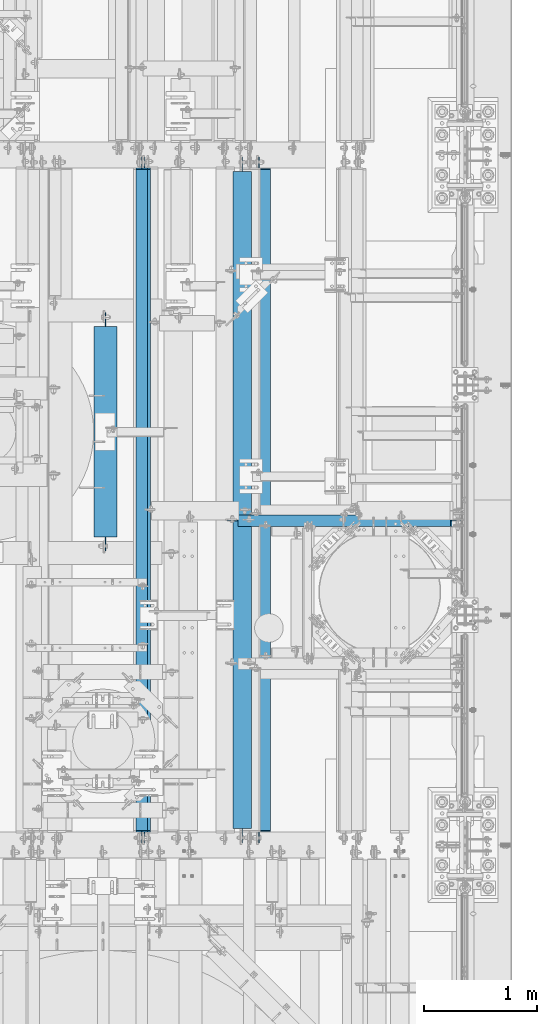
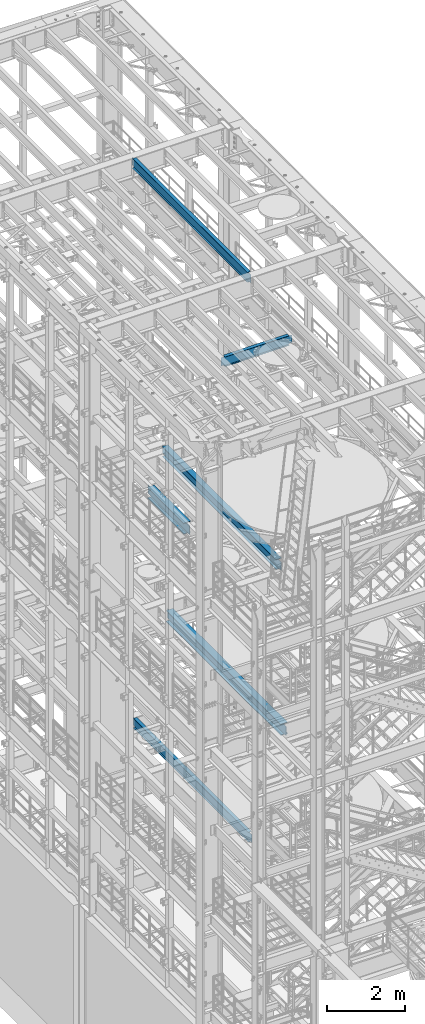
# One storey, part 1031 of 1876: 6 beams, 6 elements without a shape of their own.
"""IFC2X3 building model written with IfcOpenShell, lengths in millimetres."""

from ifc_helpers import new_model, si_unit, frame, origin_with_axes, place, context, subcontext, project, spatial, faceted_brep, material, type_object, element, aggregate, save


model = new_model("IFC2X3")

# Units and contexts
model_context = context("Model", 3, precision=1e-05, world=origin_with_axes())
body_context = subcontext(model_context, "Body", "Model", "MODEL_VIEW")
ifc_project = project(units=[si_unit("LENGTHUNIT", "METRE", prefix="MILLI"), si_unit("AREAUNIT", "SQUARE_METRE"), si_unit("VOLUMEUNIT", "CUBIC_METRE"), si_unit("MASSUNIT", "GRAM", prefix="KILO"), si_unit("TIMEUNIT", "SECOND"), si_unit("PLANEANGLEUNIT", "RADIAN"), si_unit("SOLIDANGLEUNIT", "STERADIAN"), si_unit("THERMODYNAMICTEMPERATUREUNIT", "DEGREE_CELSIUS"), si_unit("LUMINOUSINTENSITYUNIT", "LUMEN")], contexts=[model_context])

# Site, building, storey
site_placement = place(None, origin_with_axes())
site = spatial("IfcSite", under=ifc_project, at=site_placement, CompositionType="ELEMENT")
building_placement = place(site_placement, origin_with_axes())
building = spatial("IfcBuilding", under=site, at=building_placement, Name="Undefined", CompositionType="ELEMENT")
storey_placement = place(building_placement, origin_with_axes())
storey = spatial("IfcBuildingStorey", under=building, at=storey_placement, Name="Undefined", CompositionType="ELEMENT", Elevation=0.0)

# Assembly, beam
assembly_1_placement = place(storey_placement, origin_with_axes())
assembly_1 = element("IfcElementAssembly", 1, at=assembly_1_placement, inside=storey, Name="BEAM", AssemblyPlace="NOTDEFINED", PredefinedType="RIGID_FRAME")
ifc_material = material(Name="STEEL/A992")
beam_type_1 = type_object("IfcBeamType", Name="W12X16", PredefinedType="NOTDEFINED")
beam_1_placement = place(assembly_1_placement, frame((5638.8, 4387.85, 17830.8), z_axis=(0.0, 0.0, 1.0), x_axis=(1.0, 0.0, 0.0)))
beam_1 = element("IfcBeam", 2, at=beam_1_placement, type_object=beam_type_1, material=ifc_material, Name="BEAM", ObjectType="W12X16", context=body_context, shape_type="Brep", body=[
    faceted_brep([(1866.10625, -3.17500000000018, -146.049999999999), (1866.10625, -50.8000000000002, -146.049999999999), (1866.10625, -50.8000000000002, -152.400000000001), (1866.10625, 50.8000000000002, -152.400000000001), (1866.10625, 50.8000000000002, -146.049999999999), (1866.10625, 3.17500000000018, -146.049999999999), (1866.10625, 3.17500000000018, -139.699999809261), (1866.10625, -3.17500000000018, -139.699999809261), (1867.07297992259, 3.17500000000018, -134.839920291215), (1867.07297992259, -3.17500000000018, -134.839920291215), (1869.82599382306, 3.17500000000018, -130.719743823061), (1869.82599382306, -3.17500000000018, -130.719743823061), (1873.94617029122, 3.17500000000018, -127.966729922584), (1873.94617029122, -3.17500000000018, -127.966729922584), (1878.80624980926, 3.17500000000018, -126.999999999996), (1878.80624980926, -3.17500000000018, -126.999999999996), (1961.35625, -3.17500000000018, -126.999999999996), (1961.35625, 3.17500000000018, -126.999999999996), (-25.3999999999996, 3.17500000000018, 146.049999999999), (-25.3999999999996, 50.8000000000002, 146.049999999999), (1853.40625, 50.8000000000002, 146.049999999999), (1853.40625, 3.17500000000018, 146.049999999999), (-25.3999999999996, -3.17500000000018, -139.699999809269), (-25.3999999999996, 3.17500000000018, -139.699999809269), (-25.3999999999996, 3.17500000000018, -146.049999999999), (-25.3999999999996, 50.8000000000002, -146.049999999999), (-25.3999999999996, 50.8000000000002, -152.400000000001), (-25.3999999999996, -50.8000000000002, -152.400000000001), (-25.3999999999996, -50.8000000000002, -146.049999999999), (-25.3999999999996, -3.17500000000018, -146.049999999999), (-26.3667299225872, -3.17500000000018, -134.839920291222), (-26.3667299225872, 3.17500000000018, -134.839920291222), (-29.1197438230656, -3.17500000000018, -130.719743823069), (-29.1197438230656, 3.17500000000018, -130.719743823069), (-33.2399202912193, -3.17500000000018, -127.966729922591), (-33.2399202912193, 3.17500000000018, -127.966729922591), (-38.0999998092648, -3.17500000000018, -127.000000000004), (-38.0999998092648, 3.17500000000018, -127.000000000004), (-120.65, -3.17500000000018, -127.000000000004), (-120.65, 3.17500000000018, -127.000000000004), (-120.65, -3.17500000000018, 126.999999999996), (-120.65, 3.17500000000018, 126.999999999996), (-38.0999998092648, -3.17500000000018, 126.999999999996), (-38.0999998092648, 3.17500000000018, 126.999999999996), (-33.2399202912193, -3.17500000000018, 127.966729922584), (-33.2399202912193, 3.17500000000018, 127.966729922584), (-29.1197438230656, -3.17500000000018, 130.719743823061), (-29.1197438230656, 3.17500000000018, 130.719743823061), (-26.3667299225872, -3.17500000000018, 134.839920291215), (-26.3667299225872, 3.17500000000018, 134.839920291215), (-25.3999999999996, -3.17500000000018, 139.699999809261), (-25.3999999999996, 3.17500000000018, 139.699999809261), (-25.3999999999996, -50.8000000000002, 152.400000000001), (-25.3999999999996, 50.8000000000002, 152.400000000001), (-25.3999999999996, -3.17500000000018, 146.049999999999), (-25.3999999999996, -50.8000000000002, 146.049999999999), (1853.40625, -3.17500000000018, 146.049999999999), (1853.40625, -50.8000000000002, 146.049999999999), (1853.40625, -50.8000000000002, 152.400000000001), (1853.40625, 50.8000000000002, 152.400000000001), (1853.40625, -3.17500000000018, 126.999999809268), (1853.40625, 3.17500000000018, 126.999999809268), (1854.37297992259, -3.17500000000018, 122.139920291222), (1854.37297992259, 3.17500000000018, 122.139920291222), (1857.12599382306, -3.17500000000018, 118.019743823068), (1857.12599382306, 3.17500000000018, 118.019743823068), (1861.24617029122, -3.17500000000018, 115.26672992259), (1861.24617029122, 3.17500000000018, 115.26672992259), (1866.10624980926, -3.17500000000018, 114.300000000003), (1866.10624980926, 3.17500000000018, 114.300000000003), (1961.35625, -3.17500000000018, 114.300000000003), (1961.35625, 3.17500000000018, 114.300000000003)], [[[0, 1, 2, 3, 4, 5, 6, 7]], [[7, 6, 8, 9]], [[9, 8, 10, 11]], [[11, 10, 12, 13]], [[13, 12, 14, 15]], [[16, 15, 14, 17]], [[18, 19, 20, 21]], [[22, 23, 24, 25, 26, 27, 28, 29]], [[30, 31, 23, 22]], [[32, 33, 31, 30]], [[34, 35, 33, 32]], [[36, 37, 35, 34]], [[38, 39, 37, 36]], [[40, 41, 39, 38]], [[42, 43, 41, 40]], [[44, 45, 43, 42]], [[46, 47, 45, 44]], [[48, 49, 47, 46]], [[50, 51, 49, 48]], [[52, 53, 19, 18, 51, 50, 54, 55]], [[55, 54, 56, 57]], [[52, 55, 57, 58]], [[53, 52, 58, 59]], [[19, 53, 59, 20]], [[58, 57, 56, 60, 61, 21, 20, 59]], [[62, 63, 61, 60]], [[64, 65, 63, 62]], [[66, 67, 65, 64]], [[68, 69, 67, 66]], [[70, 71, 69, 68]], [[71, 70, 16, 17]], [[12, 10, 8, 6, 5, 24, 23, 31, 33, 35, 37, 39, 41, 43, 45, 47, 49, 51, 18, 21, 61, 63, 65, 67, 69, 71, 17, 14]], [[25, 24, 5, 4]], [[26, 25, 4, 3]], [[27, 26, 3, 2]], [[28, 27, 2, 1]], [[29, 28, 1, 0]], [[70, 68, 66, 64, 62, 60, 56, 54, 50, 48, 46, 44, 42, 40, 38, 36, 34, 32, 30, 22, 29, 0, 7, 9, 11, 13, 15, 16]]]),
])
aggregate(assembly_1, [beam_1])

assembly_2_placement = place(storey_placement, origin_with_axes())
assembly_2 = element("IfcElementAssembly", 3, at=assembly_2_placement, inside=storey, Name="BEAM", AssemblyPlace="NOTDEFINED", PredefinedType="RIGID_FRAME")
beam_2_placement = place(assembly_2_placement, frame((4762.5, 1524.0, 22402.8), z_axis=(0.0, 0.0, 1.0), x_axis=(0.0, 1.0, 0.0)))
beam_2 = element("IfcBeam", 4, at=beam_2_placement, type_object=beam_type_1, material=ifc_material, Name="BEAM", ObjectType="W12X16", context=body_context, shape_type="Brep", body=[
    faceted_brep([(19.84375, -3.17499999999995, -126.999999999996), (19.84375, 3.17499999999995, -126.999999999996), (102.393750190735, 3.17500000000018, -127.000000000001), (102.393750190735, -3.17500000000018, -127.000000000001), (107.25382970878, 3.17500000000018, -127.966729922588), (107.25382970878, -3.17500000000018, -127.966729922588), (111.374006176934, 3.17500000000018, -130.719743823067), (111.374006176934, -3.17500000000018, -130.719743823067), (114.127020077412, 3.17500000000018, -134.839920291221), (114.127020077412, -3.17500000000018, -134.839920291221), (115.09375, -3.17500000000018, -139.699999809266), (115.09375, 3.17500000000018, -139.699999809266), (115.09375, 3.17500000000018, -146.05), (115.09375, 50.8000000000002, -146.05), (115.09375, 50.8000000000002, -152.4), (115.09375, -50.8000000000002, -152.4), (115.09375, -50.8000000000002, -146.05), (115.09375, -3.17500000000018, -146.05), (127.79375, 3.17500000000018, 146.05), (127.79375, 50.8000000000002, 146.05), (5968.20625, 50.8, 146.05), (5968.20625, 3.17499999999995, 146.05), (115.093750190735, -3.17500000000018, 114.299999999999), (115.093750190735, 3.17500000000018, 114.299999999999), (19.84375, 3.17500000000018, 114.299999999999), (19.84375, -3.17500000000018, 114.299999999999), (119.95382970878, -3.17500000000018, 115.266729922587), (119.95382970878, 3.17500000000018, 115.266729922587), (124.074006176934, -3.17500000000018, 118.019743823065), (124.074006176934, 3.17500000000018, 118.019743823065), (126.827020077412, -3.17500000000018, 122.139920291219), (126.827020077412, 3.17500000000018, 122.139920291219), (127.79375, -3.17500000000018, 126.999999809264), (127.79375, 3.17500000000018, 126.999999809264), (127.79375, 50.8000000000002, 152.4), (127.79375, -50.8000000000002, 152.4), (5968.20625, -50.8, 152.4), (5968.20625, 50.8, 152.4), (127.79375, -50.8000000000002, 146.05), (5968.20625, -50.8, 146.05), (127.79375, -3.17500000000018, 146.05), (5968.20625, -3.17499999999995, 146.05), (5968.20625, -3.17499999999995, 126.999999809264), (5968.20625, 3.17499999999995, 126.999999809264), (5969.17297992259, -3.17499999999995, 122.139920291219), (5969.17297992259, 3.17499999999995, 122.139920291219), (5971.92599382307, -3.17499999999995, 118.019743823065), (5971.92599382307, 3.17499999999995, 118.019743823065), (5976.04617029122, -3.17499999999995, 115.266729922587), (5976.04617029122, 3.17499999999995, 115.266729922587), (5980.90624980927, -3.17499999999995, 114.299999999999), (5980.90624980927, 3.17499999999995, 114.299999999999), (6076.15625, -3.17499999999995, 114.299999999999), (6076.15625, 3.17499999999995, 114.299999999999), (6076.15625, -3.17499999999995, -126.999999999996), (6076.15625, 3.17499999999995, -126.999999999996), (5993.60624980927, -3.17499999999995, -127.000000000001), (5993.60624980927, 3.17499999999995, -127.000000000001), (5988.74617029122, -3.17499999999995, -127.966729922588), (5988.74617029122, 3.17499999999995, -127.966729922588), (5984.62599382307, -3.17499999999995, -130.719743823067), (5984.62599382307, 3.17499999999995, -130.719743823067), (5981.87297992259, -3.17499999999995, -134.839920291221), (5981.87297992259, 3.17499999999995, -134.839920291221), (5980.90625, -3.17499999999995, -139.699999809266), (5980.90625, 3.17499999999995, -139.699999809266), (5980.90625, -3.17499999999995, -146.05), (5980.90625, -50.8, -146.05), (5980.90625, -50.8, -152.4), (5980.90625, 50.8, -152.4), (5980.90625, 50.8, -146.05), (5980.90625, 3.17499999999995, -146.05)], [[[0, 1, 2, 3]], [[3, 2, 4, 5]], [[5, 4, 6, 7]], [[7, 6, 8, 9]], [[10, 11, 12, 13, 14, 15, 16, 17]], [[9, 8, 11, 10]], [[18, 19, 20, 21]], [[22, 23, 24, 25]], [[26, 27, 23, 22]], [[28, 29, 27, 26]], [[30, 31, 29, 28]], [[32, 33, 31, 30]], [[34, 35, 36, 37]], [[35, 38, 39, 36]], [[38, 40, 41, 39]], [[35, 34, 19, 18, 33, 32, 40, 38]], [[19, 34, 37, 20]], [[36, 39, 41, 42, 43, 21, 20, 37]], [[44, 45, 43, 42]], [[46, 47, 45, 44]], [[48, 49, 47, 46]], [[50, 51, 49, 48]], [[52, 53, 51, 50]], [[53, 52, 54, 55]], [[54, 56, 57, 55]], [[58, 59, 57, 56]], [[60, 61, 59, 58]], [[62, 63, 61, 60]], [[64, 65, 63, 62]], [[66, 67, 68, 69, 70, 71, 65, 64]], [[17, 16, 67, 66]], [[16, 15, 68, 67]], [[15, 14, 69, 68]], [[14, 13, 70, 69]], [[13, 12, 71, 70]], [[59, 61, 63, 65, 71, 12, 11, 8, 6, 4, 2, 1, 24, 23, 27, 29, 31, 33, 18, 21, 43, 45, 47, 49, 51, 53, 55, 57]], [[25, 24, 1, 0]], [[52, 50, 48, 46, 44, 42, 41, 40, 32, 30, 28, 26, 22, 25, 0, 3, 5, 7, 9, 10, 17, 66, 64, 62, 60, 58, 56, 54]]]),
])
aggregate(assembly_2, [beam_2])

assembly_3_placement = place(storey_placement, origin_with_axes())
assembly_3 = element("IfcElementAssembly", 5, at=assembly_3_placement, inside=storey, Name="BEAM", AssemblyPlace="NOTDEFINED", PredefinedType="RIGID_FRAME")
beam_3_placement = place(assembly_3_placement, frame((4787.9, 1524.0, 4978.4), z_axis=(0.0, 0.0, 1.0), x_axis=(0.0, 1.0, 0.0)))
beam_3 = element("IfcBeam", 6, at=beam_3_placement, type_object=beam_type_1, material=ifc_material, Name="BEAM", ObjectType="W12X16", context=body_context, shape_type="Brep", body=[
    faceted_brep([(19.84375, -3.17499999999995, -126.999999999996), (19.84375, 3.17499999999995, -126.999999999996), (102.393750190735, 3.17500000000018, -127.000000000001), (102.393750190735, -3.17500000000018, -127.000000000001), (107.25382970878, 3.17500000000018, -127.966729922588), (107.25382970878, -3.17500000000018, -127.966729922588), (111.374006176934, 3.17500000000018, -130.719743823067), (111.374006176934, -3.17500000000018, -130.719743823067), (114.127020077412, 3.17500000000018, -134.839920291221), (114.127020077412, -3.17500000000018, -134.839920291221), (115.09375, -3.17500000000018, -139.699999809266), (115.09375, 3.17500000000018, -139.699999809266), (115.09375, 3.17500000000018, -146.05), (115.09375, 50.8000000000002, -146.05), (115.09375, 50.8000000000002, -152.4), (115.09375, -50.8000000000002, -152.4), (115.09375, -50.8000000000002, -146.05), (115.09375, -3.17500000000018, -146.05), (127.79375, 3.17500000000018, 146.05), (127.79375, 50.8000000000002, 146.05), (5968.20625, 50.8, 146.05), (5968.20625, 3.17499999999995, 146.05), (115.093750190735, -3.17500000000018, 114.299999999999), (115.093750190735, 3.17500000000018, 114.299999999999), (19.84375, 3.17500000000018, 114.299999999999), (19.84375, -3.17500000000018, 114.299999999999), (119.95382970878, -3.17500000000018, 115.266729922587), (119.95382970878, 3.17500000000018, 115.266729922587), (124.074006176934, -3.17500000000018, 118.019743823065), (124.074006176934, 3.17500000000018, 118.019743823065), (126.827020077412, -3.17500000000018, 122.139920291219), (126.827020077412, 3.17500000000018, 122.139920291219), (127.79375, -3.17500000000018, 126.999999809264), (127.79375, 3.17500000000018, 126.999999809264), (127.79375, 50.8000000000002, 152.4), (127.79375, -50.8000000000002, 152.4), (5968.20625, -50.8, 152.4), (5968.20625, 50.8, 152.4), (127.79375, -50.8000000000002, 146.05), (5968.20625, -50.8, 146.05), (127.79375, -3.17500000000018, 146.05), (5968.20625, -3.17499999999995, 146.05), (5968.20625, -3.17499999999995, 126.999999809264), (5968.20625, 3.17499999999995, 126.999999809264), (5969.17297992259, -3.17499999999995, 122.139920291219), (5969.17297992259, 3.17499999999995, 122.139920291219), (5971.92599382307, -3.17499999999995, 118.019743823065), (5971.92599382307, 3.17499999999995, 118.019743823065), (5976.04617029122, -3.17499999999995, 115.266729922587), (5976.04617029122, 3.17499999999995, 115.266729922587), (5980.90624980927, -3.17499999999995, 114.299999999999), (5980.90624980927, 3.17499999999995, 114.299999999999), (6076.15625, -3.17499999999995, 114.299999999999), (6076.15625, 3.17499999999995, 114.299999999999), (6076.15625, -3.17499999999995, -126.999999999996), (6076.15625, 3.17499999999995, -126.999999999996), (5993.60624980927, -3.17499999999995, -127.000000000001), (5993.60624980927, 3.17499999999995, -127.000000000001), (5988.74617029122, -3.17499999999995, -127.966729922588), (5988.74617029122, 3.17499999999995, -127.966729922588), (5984.62599382307, -3.17499999999995, -130.719743823067), (5984.62599382307, 3.17499999999995, -130.719743823067), (5981.87297992259, -3.17499999999995, -134.839920291221), (5981.87297992259, 3.17499999999995, -134.839920291221), (5980.90625, -3.17499999999995, -139.699999809266), (5980.90625, 3.17499999999995, -139.699999809266), (5980.90625, -3.17499999999995, -146.05), (5980.90625, -50.8, -146.05), (5980.90625, -50.8, -152.4), (5980.90625, 50.8, -152.4), (5980.90625, 50.8, -146.05), (5980.90625, 3.17499999999995, -146.05)], [[[0, 1, 2, 3]], [[3, 2, 4, 5]], [[5, 4, 6, 7]], [[7, 6, 8, 9]], [[10, 11, 12, 13, 14, 15, 16, 17]], [[9, 8, 11, 10]], [[18, 19, 20, 21]], [[22, 23, 24, 25]], [[26, 27, 23, 22]], [[28, 29, 27, 26]], [[30, 31, 29, 28]], [[32, 33, 31, 30]], [[34, 35, 36, 37]], [[35, 38, 39, 36]], [[38, 40, 41, 39]], [[35, 34, 19, 18, 33, 32, 40, 38]], [[19, 34, 37, 20]], [[36, 39, 41, 42, 43, 21, 20, 37]], [[44, 45, 43, 42]], [[46, 47, 45, 44]], [[48, 49, 47, 46]], [[50, 51, 49, 48]], [[52, 53, 51, 50]], [[53, 52, 54, 55]], [[54, 56, 57, 55]], [[58, 59, 57, 56]], [[60, 61, 59, 58]], [[62, 63, 61, 60]], [[64, 65, 63, 62]], [[66, 67, 68, 69, 70, 71, 65, 64]], [[17, 16, 67, 66]], [[16, 15, 68, 67]], [[15, 14, 69, 68]], [[14, 13, 70, 69]], [[13, 12, 71, 70]], [[59, 61, 63, 65, 71, 12, 11, 8, 6, 4, 2, 1, 24, 23, 27, 29, 31, 33, 18, 21, 43, 45, 47, 49, 51, 53, 55, 57]], [[25, 24, 1, 0]], [[52, 50, 48, 46, 44, 42, 41, 40, 32, 30, 28, 26, 22, 25, 0, 3, 5, 7, 9, 10, 17, 66, 64, 62, 60, 58, 56, 54]]]),
])
aggregate(assembly_3, [beam_3])

assembly_4_placement = place(storey_placement, origin_with_axes())
assembly_4 = element("IfcElementAssembly", 7, at=assembly_4_placement, inside=storey, Name="BEAM", AssemblyPlace="NOTDEFINED", PredefinedType="RIGID_FRAME")
beam_type_2 = type_object("IfcBeamType", Name="W12X30", PredefinedType="NOTDEFINED")
beam_4_placement = place(assembly_4_placement, frame((5651.5, 1524.0, 13152.4375), z_axis=(0.0, 0.0, 1.0), x_axis=(0.0, 1.0, 0.0)))
beam_4 = element("IfcBeam", 8, at=beam_4_placement, type_object=beam_type_2, material=ifc_material, Name="BEAM", ObjectType="W12X30", context=body_context, shape_type="Brep", body=[
    faceted_brep([(19.8437500000002, -3.17500000000018, -131.762499999993), (19.8437500000002, 3.17500000000018, -131.762499999993), (134.143750190735, 3.17500000000018, -131.762500000001), (134.143750190735, -3.17500000000018, -131.762500000001), (139.00382970878, 3.17500000000018, -132.729229922588), (139.00382970878, -3.17500000000018, -132.729229922588), (143.124006176934, 3.17500000000018, -135.482243823066), (143.124006176934, -3.17500000000018, -135.482243823066), (145.877020077412, 3.17500000000018, -139.602420291219), (145.877020077412, -3.17500000000018, -139.602420291219), (146.84375, -3.17500000000018, -144.462499809266), (146.84375, 3.17500000000018, -144.462499809266), (146.84375, 3.17500000000018, -146.049999999999), (146.84375, 82.5500000000002, -146.049999999999), (146.84375, 82.5500000000002, -157.1625), (146.84375, -82.5500000000002, -157.1625), (146.84375, -82.5500000000002, -146.049999999999), (146.84375, -3.17500000000018, -146.049999999999), (5949.15625, 82.5500000000002, 146.049999999999), (5949.15625, 3.17500000000018, 146.049999999999), (146.84375, 3.17500000000018, 146.049999999999), (146.84375, 82.5500000000002, 146.049999999999), (134.143750190735, -3.17500000000018, 119.0625), (134.143750190735, 3.17500000000018, 119.0625), (19.8437491105051, 3.17499999999995, 119.062500000004), (19.8437491105051, -3.17499999999995, 119.062500000004), (139.00382970878, -3.17500000000018, 120.029229922588), (139.00382970878, 3.17500000000018, 120.029229922588), (143.124006176934, -3.17500000000018, 122.782243823065), (143.124006176934, 3.17500000000018, 122.782243823065), (145.877020077412, -3.17500000000018, 126.902420291219), (145.877020077412, 3.17500000000018, 126.902420291219), (146.84375, -3.17500000000018, 131.762499809265), (146.84375, 3.17500000000018, 131.762499809265), (5949.15625, -82.5500000000002, 157.1625), (5949.15625, 82.5500000000002, 157.1625), (146.84375, 82.5500000000002, 157.1625), (146.84375, -82.5500000000002, 157.1625), (5949.15625, -82.5500000000002, 146.049999999999), (146.84375, -82.5500000000002, 146.049999999999), (5949.15625, -3.17500000000018, 146.049999999999), (146.84375, -3.17500000000018, 146.049999999999), (5949.15625, -3.17500000000018, 131.762499809265), (5949.15625, 3.17500000000018, 131.762499809265), (5950.12297992259, -3.17500000000018, 126.902420291219), (5950.12297992259, 3.17500000000018, 126.902420291219), (5952.87599382307, -3.17500000000018, 122.782243823065), (5952.87599382307, 3.17500000000018, 122.782243823065), (5956.99617029122, -3.17500000000018, 120.029229922588), (5956.99617029122, 3.17500000000018, 120.029229922588), (5961.85624980927, -3.17500000000018, 119.0625), (5961.85624980927, 3.17500000000018, 119.0625), (6076.15624911051, -3.17499999999995, 119.062500000004), (6076.15624911051, 3.17499999999995, 119.062500000004), (6076.15625, -3.17500000000018, -131.762499999993), (6076.15625, 3.17500000000018, -131.762499999993), (5961.85624980927, -3.17500000000018, -131.762500000001), (5961.85624980927, 3.17500000000018, -131.762500000001), (5956.99617029122, -3.17500000000018, -132.729229922588), (5956.99617029122, 3.17500000000018, -132.729229922588), (5952.87599382307, -3.17500000000018, -135.482243823066), (5952.87599382307, 3.17500000000018, -135.482243823066), (5950.12297992259, -3.17500000000018, -139.602420291219), (5950.12297992259, 3.17500000000018, -139.602420291219), (5949.15625, -3.17500000000018, -144.462499809266), (5949.15625, 3.17500000000018, -144.462499809266), (5949.15625, -3.17500000000018, -146.049999999999), (5949.15625, -82.5500000000002, -146.049999999999), (5949.15625, -82.5500000000002, -157.1625), (5949.15625, 82.5500000000002, -157.1625), (5949.15625, 82.5500000000002, -146.049999999999), (5949.15625, 3.17500000000018, -146.049999999999)], [[[0, 1, 2, 3]], [[3, 2, 4, 5]], [[5, 4, 6, 7]], [[7, 6, 8, 9]], [[10, 11, 12, 13, 14, 15, 16, 17]], [[9, 8, 11, 10]], [[18, 19, 20, 21]], [[22, 23, 24, 25]], [[26, 27, 23, 22]], [[28, 29, 27, 26]], [[30, 31, 29, 28]], [[32, 33, 31, 30]], [[34, 35, 36, 37]], [[38, 34, 37, 39]], [[40, 38, 39, 41]], [[37, 36, 21, 20, 33, 32, 41, 39]], [[35, 18, 21, 36]], [[34, 38, 40, 42, 43, 19, 18, 35]], [[44, 45, 43, 42]], [[46, 47, 45, 44]], [[48, 49, 47, 46]], [[50, 51, 49, 48]], [[52, 53, 51, 50]], [[53, 52, 54, 55]], [[54, 56, 57, 55]], [[58, 59, 57, 56]], [[60, 61, 59, 58]], [[62, 63, 61, 60]], [[64, 65, 63, 62]], [[66, 67, 68, 69, 70, 71, 65, 64]], [[67, 66, 17, 16]], [[68, 67, 16, 15]], [[69, 68, 15, 14]], [[70, 69, 14, 13]], [[71, 70, 13, 12]], [[6, 4, 2, 1, 24, 23, 27, 29, 31, 33, 20, 19, 43, 45, 47, 49, 51, 53, 55, 57, 59, 61, 63, 65, 71, 12, 11, 8]], [[25, 24, 1, 0]], [[66, 64, 62, 60, 58, 56, 54, 52, 50, 48, 46, 44, 42, 40, 41, 32, 30, 28, 26, 22, 25, 0, 3, 5, 7, 9, 10, 17]]]),
])
aggregate(assembly_4, [beam_4])

assembly_5_placement = place(storey_placement, origin_with_axes())
assembly_5 = element("IfcElementAssembly", 9, at=assembly_5_placement, inside=storey, Name="BEAM", AssemblyPlace="NOTDEFINED", PredefinedType="RIGID_FRAME")
beam_type_3 = type_object("IfcBeamType", Name="W14X48", PredefinedType="NOTDEFINED")
beam_5_placement = place(assembly_5_placement, frame((4441.825, 4057.65, 13134.975), z_axis=(0.0, 0.0, 1.0), x_axis=(0.0, 1.0, 0.0)))
beam_5 = element("IfcBeam", 10, at=beam_5_placement, type_object=beam_type_3, material=ifc_material, Name="BEAM", ObjectType="W14X48", context=body_context, shape_type="Brep", body=[
    faceted_brep([(2045.49375, -3.96875, -158.75), (2045.49375, -101.6, -158.75), (2045.49375, -101.6, -174.625), (2045.49375, 101.6, -174.625), (2045.49375, 101.6, -158.75), (2045.49375, 3.96875, -158.75), (2045.49375, 3.96875, -149.224999809265), (2045.49375, -3.96875, -149.224999809265), (2046.46047992259, 3.96875, -144.364920291218), (2046.46047992259, -3.96875, -144.364920291218), (2049.21349382307, 3.96875, -140.244743823065), (2049.21349382307, -3.96875, -140.244743823065), (2053.33367029122, 3.96875, -137.491729922587), (2053.33367029122, -3.96875, -137.491729922587), (2058.19374980927, 3.96875, -136.525), (2058.19374980927, -3.96875, -136.525), (2172.49375, -3.96875, -136.525), (2172.49375, 3.96875, -136.525), (189.70625, 3.96875, 158.75), (189.70625, 101.6, 158.75), (2045.49375, 101.6, 158.75), (2045.49375, 3.96875, 158.75), (189.70625, -3.96875, -149.224999809265), (189.70625, 3.96875, -149.224999809265), (189.70625, 3.96875, -158.75), (189.70625, 101.6, -158.75), (189.70625, 101.6, -174.625), (189.70625, -101.6, -174.625), (189.70625, -101.6, -158.75), (189.70625, -3.96875, -158.75), (188.739520077413, -3.96875, -144.364920291218), (188.739520077413, 3.96875, -144.364920291218), (185.986506176934, -3.96875, -140.244743823065), (185.986506176934, 3.96875, -140.244743823065), (181.866329708781, -3.96875, -137.491729922587), (181.866329708781, 3.96875, -137.491729922587), (177.006250190735, -3.96875, -136.525), (177.006250190735, 3.96875, -136.525), (62.7062500000002, -3.96875, -136.525), (62.7062500000002, 3.96875, -136.525), (62.7062500000002, -3.96875, 136.525), (62.7062500000002, 3.96875, 136.525), (177.006250190735, -3.96875, 136.525), (177.006250190735, 3.96875, 136.525), (181.866329708781, -3.96875, 137.491729922587), (181.866329708781, 3.96875, 137.491729922587), (185.986506176934, -3.96875, 140.244743823065), (185.986506176934, 3.96875, 140.244743823065), (188.739520077413, -3.96875, 144.364920291218), (188.739520077413, 3.96875, 144.364920291218), (189.70625, -3.96875, 149.224999809265), (189.70625, 3.96875, 149.224999809265), (189.70625, -101.6, 174.625), (189.70625, 101.6, 174.625), (189.70625, -3.96875, 158.75), (189.70625, -101.6, 158.75), (2045.49375, -3.96875, 158.75), (2045.49375, -101.6, 158.75), (2045.49375, -101.6, 174.625), (2045.49375, 101.6, 174.625), (2045.49375, -3.96875, 149.224999809265), (2045.49375, 3.96875, 149.224999809265), (2046.46047992259, -3.96875, 144.364920291218), (2046.46047992259, 3.96875, 144.364920291218), (2049.21349382307, -3.96875, 140.244743823065), (2049.21349382307, 3.96875, 140.244743823065), (2053.33367029122, -3.96875, 137.491729922587), (2053.33367029122, 3.96875, 137.491729922587), (2058.19374980927, -3.96875, 136.525), (2058.19374980927, 3.96875, 136.525), (2172.49375, -3.96875, 136.525), (2172.49375, 3.96875, 136.525)], [[[0, 1, 2, 3, 4, 5, 6, 7]], [[7, 6, 8, 9]], [[9, 8, 10, 11]], [[11, 10, 12, 13]], [[13, 12, 14, 15]], [[16, 15, 14, 17]], [[18, 19, 20, 21]], [[22, 23, 24, 25, 26, 27, 28, 29]], [[30, 31, 23, 22]], [[32, 33, 31, 30]], [[34, 35, 33, 32]], [[36, 37, 35, 34]], [[38, 39, 37, 36]], [[40, 41, 39, 38]], [[42, 43, 41, 40]], [[44, 45, 43, 42]], [[46, 47, 45, 44]], [[48, 49, 47, 46]], [[50, 51, 49, 48]], [[52, 53, 19, 18, 51, 50, 54, 55]], [[55, 54, 56, 57]], [[52, 55, 57, 58]], [[53, 52, 58, 59]], [[19, 53, 59, 20]], [[58, 57, 56, 60, 61, 21, 20, 59]], [[62, 63, 61, 60]], [[64, 65, 63, 62]], [[66, 67, 65, 64]], [[68, 69, 67, 66]], [[70, 71, 69, 68]], [[71, 70, 16, 17]], [[12, 10, 8, 6, 5, 24, 23, 31, 33, 35, 37, 39, 41, 43, 45, 47, 49, 51, 18, 21, 61, 63, 65, 67, 69, 71, 17, 14]], [[25, 24, 5, 4]], [[26, 25, 4, 3]], [[27, 26, 3, 2]], [[28, 27, 2, 1]], [[29, 28, 1, 0]], [[70, 68, 66, 64, 62, 60, 56, 54, 50, 48, 46, 44, 42, 40, 38, 36, 34, 32, 30, 22, 29, 0, 7, 9, 11, 13, 15, 16]]]),
])
aggregate(assembly_5, [beam_5])

assembly_6_placement = place(storey_placement, origin_with_axes())
assembly_6 = element("IfcElementAssembly", 11, at=assembly_6_placement, inside=storey, Name="BEAM", AssemblyPlace="NOTDEFINED", PredefinedType="RIGID_FRAME")
beam_6_placement = place(assembly_6_placement, frame((5797.55, 1524.0, 7978.775), z_axis=(0.0, 0.0, 1.0), x_axis=(0.0, 1.0, 0.0)))
beam_6 = element("IfcBeam", 12, at=beam_6_placement, type_object=beam_type_3, material=ifc_material, Name="BEAM", ObjectType="W14X48", context=body_context, shape_type="Brep", body=[
    faceted_brep([(19.8437500000002, -3.96875, -149.225000000001), (19.8437500000002, 3.96875, -149.225000000001), (108.743750190735, 3.96875, -149.225000000001), (108.743750190735, -3.96875, -149.225000000001), (113.60382970878, 3.96875, -150.191729922589), (113.60382970878, -3.96875, -150.191729922589), (117.724006176934, 3.96875, -152.944743823067), (117.724006176934, -3.96875, -152.944743823067), (120.477020077412, 3.96875, -157.064920291221), (120.477020077412, -3.96875, -157.064920291221), (121.44375, -101.6, -161.924999809266), (121.44375, 101.6, -161.924999809266), (121.443749999999, 101.6, -174.625), (121.443749999999, -101.6, -174.625), (120.812203271508, -101.6, -158.75), (120.812203271508, -3.96875, -158.75), (120.812203271508, 3.96875, -158.75), (120.812203271508, 101.6, -158.75), (5968.20625, 101.6, 158.75), (5968.20625, 3.96875, 158.75), (127.79375, 3.96875, 158.75), (127.79375, 101.6, 158.75), (115.093750190735, -3.96875, 136.524999999999), (115.093750190735, 3.96875, 136.524999999999), (19.8437500000002, 3.96875, 136.524999999999), (19.8437500000002, -3.96875, 136.524999999999), (119.95382970878, -3.96875, 137.491729922586), (119.95382970878, 3.96875, 137.491729922586), (124.074006176934, -3.96875, 140.244743823065), (124.074006176934, 3.96875, 140.244743823065), (126.827020077412, -3.96875, 144.364920291218), (126.827020077412, 3.96875, 144.364920291218), (127.79375, -3.96875, 149.224999809264), (127.79375, 3.96875, 149.224999809264), (5968.20625, -101.6, 174.625), (5968.20625, 101.6, 174.625), (127.79375, 101.6, 174.625), (127.79375, -101.6, 174.625), (5968.20625, -101.6, 158.75), (127.79375, -101.6, 158.75), (5968.20625, -3.96875, 158.75), (127.79375, -3.96875, 158.75), (5968.20625, -3.96875, 149.224999809264), (5968.20625, 3.96875, 149.224999809264), (5969.17297992259, -3.96875, 144.364920291218), (5969.17297992259, 3.96875, 144.364920291218), (5971.92599382307, -3.96875, 140.244743823065), (5971.92599382307, 3.96875, 140.244743823065), (5976.04617029122, -3.96875, 137.491729922586), (5976.04617029122, 3.96875, 137.491729922586), (5980.90624980927, -3.96875, 136.524999999999), (5980.90624980927, 3.96875, 136.524999999999), (6076.15625, -3.96875, 136.525), (6076.15625, 3.96875, 136.525), (6076.15625, -3.96875, -149.225000000001), (6076.15625, 3.96875, -149.225000000001), (5987.25624980927, -3.96875, -149.225000000001), (5987.25624980927, 3.96875, -149.225000000001), (5982.39617029122, -3.96875, -150.191729922589), (5982.39617029122, 3.96875, -150.191729922589), (5978.27599382307, -3.96875, -152.944743823067), (5978.27599382307, 3.96875, -152.944743823067), (5975.52297992259, -3.96875, -157.064920291221), (5975.52297992259, 3.96875, -157.064920291221), (5975.18779672849, -3.96875, -158.75), (5975.18779672849, -101.6, -158.75), (5974.55625, -101.6, -161.924999809266), (5974.55625, 101.6, -161.924999809266), (5975.18779672849, 101.6, -158.75), (5975.18779672849, 3.96875, -158.75), (5974.55625, -101.6, -174.625), (5974.55625, 101.6, -174.625)], [[[0, 1, 2, 3]], [[3, 2, 4, 5]], [[5, 4, 6, 7]], [[7, 6, 8, 9]], [[10, 11, 12, 13]], [[14, 15, 9, 8, 16, 17, 11, 10]], [[18, 19, 20, 21]], [[22, 23, 24, 25]], [[26, 27, 23, 22]], [[28, 29, 27, 26]], [[30, 31, 29, 28]], [[32, 33, 31, 30]], [[34, 35, 36, 37]], [[38, 34, 37, 39]], [[40, 38, 39, 41]], [[37, 36, 21, 20, 33, 32, 41, 39]], [[35, 18, 21, 36]], [[34, 38, 40, 42, 43, 19, 18, 35]], [[44, 45, 43, 42]], [[46, 47, 45, 44]], [[48, 49, 47, 46]], [[50, 51, 49, 48]], [[52, 53, 51, 50]], [[53, 52, 54, 55]], [[54, 56, 57, 55]], [[58, 59, 57, 56]], [[60, 61, 59, 58]], [[62, 63, 61, 60]], [[64, 65, 66, 67, 68, 69, 63, 62]], [[70, 71, 67, 66]], [[71, 70, 13, 12]], [[68, 67, 71, 12, 11, 17]], [[69, 68, 17, 16]], [[6, 4, 2, 1, 24, 23, 27, 29, 31, 33, 20, 19, 43, 45, 47, 49, 51, 53, 55, 57, 59, 61, 63, 69, 16, 8]], [[25, 24, 1, 0]], [[64, 62, 60, 58, 56, 54, 52, 50, 48, 46, 44, 42, 40, 41, 32, 30, 28, 26, 22, 25, 0, 3, 5, 7, 9, 15]], [[65, 64, 15, 14]], [[70, 66, 65, 14, 10, 13]]]),
])
aggregate(assembly_6, [beam_6])

save(model, "model.ifc")
